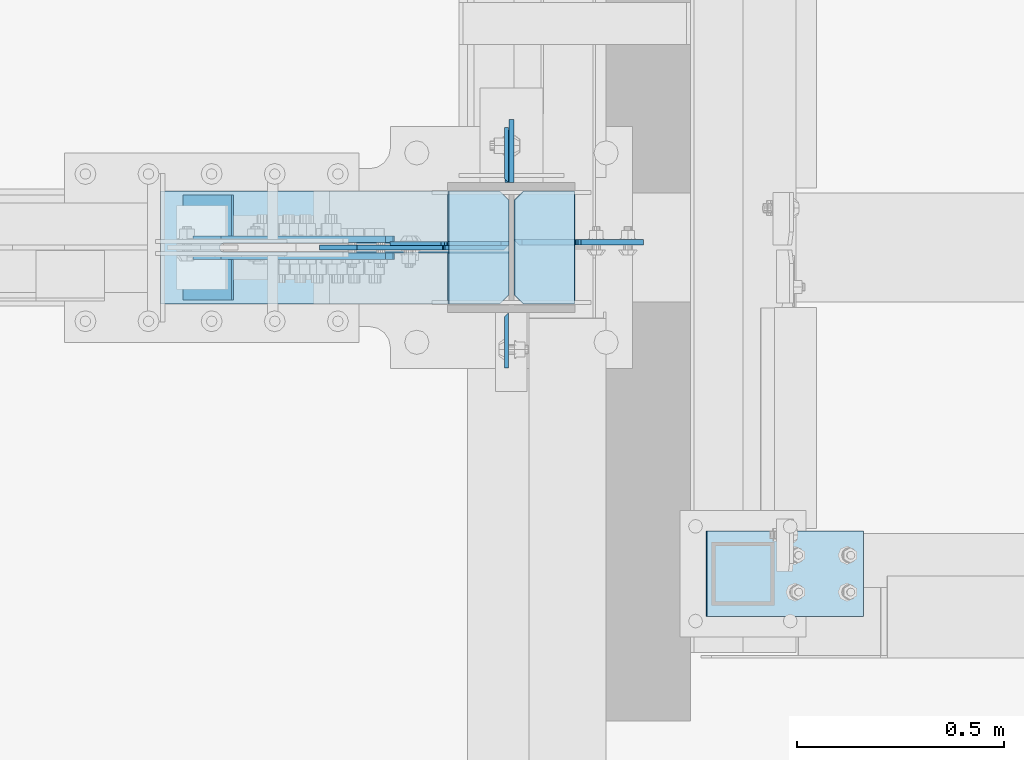
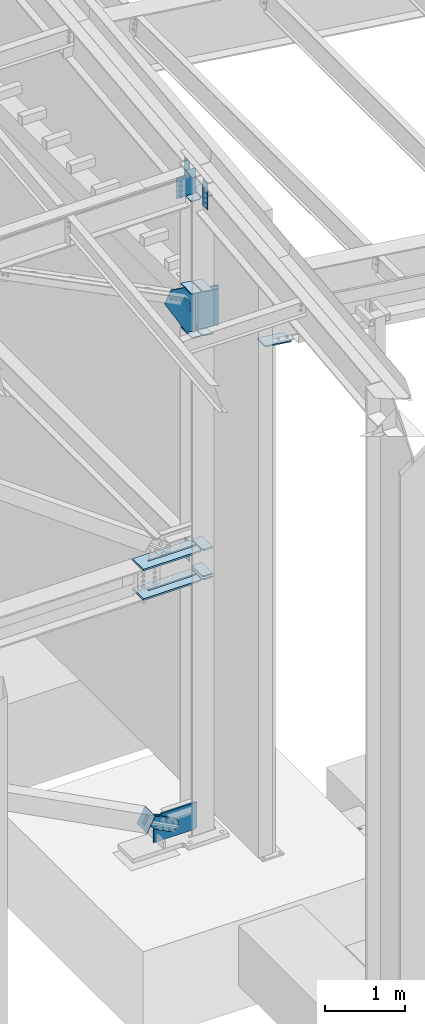
# One storey, part 1003 of 1179: 23 plates, 5 elements without a shape of their own.
"""IFC2X3 building model written with IfcOpenShell, lengths in millimetres."""

from ifc_helpers import new_model, si_unit, frame, origin_with_axes, place, context, subcontext, project, spatial, faceted_brep, material, type_object, element, aggregate, save


model = new_model("IFC2X3")

# Units and contexts
model_context = context("Model", 3, precision=1e-05, world=origin_with_axes())
body_context = subcontext(model_context, "Body", "Model", "MODEL_VIEW")
ifc_project = project(units=[si_unit("LENGTHUNIT", "METRE", prefix="MILLI"), si_unit("AREAUNIT", "SQUARE_METRE"), si_unit("VOLUMEUNIT", "CUBIC_METRE"), si_unit("MASSUNIT", "GRAM", prefix="KILO"), si_unit("TIMEUNIT", "SECOND"), si_unit("PLANEANGLEUNIT", "RADIAN"), si_unit("SOLIDANGLEUNIT", "STERADIAN"), si_unit("THERMODYNAMICTEMPERATUREUNIT", "DEGREE_CELSIUS"), si_unit("LUMINOUSINTENSITYUNIT", "LUMEN")], contexts=[model_context])

# Site, building, storey
site_placement = place(None, origin_with_axes())
site = spatial("IfcSite", under=ifc_project, at=site_placement, CompositionType="ELEMENT")
building_placement = place(site_placement, origin_with_axes())
building = spatial("IfcBuilding", under=site, at=building_placement, Name="Undefined", CompositionType="ELEMENT")
storey_placement = place(building_placement, origin_with_axes())
storey = spatial("IfcBuildingStorey", under=building, at=storey_placement, Name="Undefined", CompositionType="ELEMENT", Elevation=0.0)

# Assembly, plates
assembly_1_placement = place(storey_placement, origin_with_axes())
assembly_1 = element("IfcElementAssembly", 1, at=assembly_1_placement, inside=storey, Name="COLUMN", AssemblyPlace="NOTDEFINED", PredefinedType="RIGID_FRAME")
ifc_material_1 = material(Name="STEEL/A36")
plate_type_1 = type_object("IfcPlateType", PredefinedType="NOTDEFINED")
plate_1_placement = place(assembly_1_placement, frame((24297.48125, 5592.7625, 4051.29999886453), z_axis=(0.0, 1.0, 0.0), x_axis=(0.0, 0.0, -1.0)))
plate_1 = element("IfcPlate", 2, at=plate_1_placement, type_object=plate_type_1, material=ifc_material_1, Name="PLATE", context=body_context, shape_type="Brep", body=[
    faceted_brep([(0.0, -4.76249999999709, 0.0), (0.0, -4.76249999999709, 127.0), (0.0, 4.76249999999709, 127.0), (0.0, 4.76249999999709, 0.0), (304.799999999999, -4.76249999999982, 127.0), (304.799999999999, 4.76249999999982, 127.0), (304.799987792969, -4.76250000000073, 0.0), (304.799987792969, 4.76250000000073, 0.0)], [[[0, 1, 2, 3]], [[2, 1, 4, 5]], [[4, 6, 7, 5]], [[6, 0, 3, 7]], [[5, 7, 3, 2]], [[6, 4, 1, 0]]]),
])
ifc_material_2 = material(Name="STEEL/A572-GR.50")
plate_type_2 = type_object("IfcPlateType", PredefinedType="NOTDEFINED")
plate_2_placement = place(assembly_1_placement, frame((24314.15, 5299.075, 3641.725), z_axis=(0.0, 1.0, 0.0), x_axis=(1.0, 0.0, 0.0)))
plate_2 = element("IfcPlate", 3, at=plate_2_placement, type_object=plate_type_2, material=ifc_material_2, Name="PLATE", context=body_context, shape_type="Brep", body=[
    faceted_brep([(4.54747350886464e-12, -12.6999999999999, 22.2250003814697), (0.0, -12.6999999999998, 250.824987411499), (0.0, 12.6999999999998, 250.824987411499), (-4.54747350886464e-12, 12.6999999999999, 22.2250003814697), (22.2250003814697, -12.6999999999998, 273.049987792969), (22.2250003814697, 12.6999999999998, 273.049987792969), (146.050003051758, -12.6999999999998, 273.049987792969), (146.050003051758, 12.6999999999998, 273.049987792969), (146.050000000188, -12.7000000000003, 0.0), (146.050000000178, 12.6999999999995, 0.0), (22.2250003814834, -12.6999999999999, 0.0), (22.2250003814743, 12.6999999999998, 0.0)], [[[0, 1, 2, 3]], [[1, 4, 5, 2]], [[4, 6, 7, 5]], [[6, 8, 9, 7]], [[8, 10, 11, 9]], [[10, 0, 3, 11]], [[5, 7, 9, 11, 3, 2]], [[10, 8, 6, 4, 1, 0]]]),
])
plate_3_placement = place(assembly_1_placement, frame((24314.15, 5299.075, 4089.4), z_axis=(0.0, 1.0, 0.0), x_axis=(1.0, 0.0, 0.0)))
plate_3 = element("IfcPlate", 4, at=plate_3_placement, type_object=plate_type_2, material=ifc_material_2, Name="PLATE", context=body_context, shape_type="Brep", body=[
    faceted_brep([(4.54747350886464e-12, -12.6999999999999, 22.2250003814697), (0.0, -12.6999999999998, 250.824987411499), (0.0, 12.6999999999998, 250.824987411499), (-4.54747350886464e-12, 12.6999999999999, 22.2250003814697), (22.2250003814697, -12.6999999999998, 273.049987792969), (22.2250003814697, 12.6999999999998, 273.049987792969), (146.050003051758, -12.6999999999998, 273.049987792969), (146.050003051758, 12.6999999999998, 273.049987792969), (146.050000000188, -12.7000000000003, 0.0), (146.050000000178, 12.6999999999995, 0.0), (22.2250003814834, -12.6999999999999, 0.0), (22.2250003814743, 12.6999999999998, 0.0)], [[[0, 1, 2, 3]], [[1, 4, 5, 2]], [[4, 6, 7, 5]], [[6, 8, 9, 7]], [[8, 10, 11, 9]], [[10, 0, 3, 11]], [[5, 7, 9, 11, 3, 2]], [[10, 8, 6, 4, 1, 0]]]),
])
plate_type_3 = type_object("IfcPlateType", PredefinedType="NOTDEFINED")
plate_4_placement = place(assembly_1_placement, frame((24295.89375, 5592.76250000005, 9831.75045370011), z_axis=(0.0, 1.0, 0.0), x_axis=(0.0, 0.0, -1.0)))
plate_4 = element("IfcPlate", 5, at=plate_4_placement, type_object=plate_type_3, material=ifc_material_1, Name="PLATE", context=body_context, shape_type="Brep", body=[
    faceted_brep([(0.0, -4.76249999999709, 0.0), (0.0, 4.76250000000073, 9.52499999999964), (393.700000000001, 4.76250000000073, 9.52499999999964), (393.700000000001, -4.76250000000073, 0.0), (0.0, -4.76250000000073, 133.35), (0.0, 4.76250000000073, 133.35), (393.700000000001, -4.76250000000073, 133.35), (393.700000000001, 4.76250000000073, 133.35)], [[[0, 1, 2, 3]], [[4, 5, 1, 0]], [[4, 6, 7, 5]], [[7, 6, 3, 2]], [[5, 7, 2, 1]], [[3, 6, 4, 0]]]),
])
plate_5_placement = place(assembly_1_placement, frame((24295.89375, 5278.43749999996, 9776.14145226233), z_axis=(0.0, -1.0, 0.0), x_axis=(0.0, 0.0, -1.0)))
plate_5 = element("IfcPlate", 6, at=plate_5_placement, type_object=plate_type_3, material=ifc_material_1, Name="PLATE", context=body_context, shape_type="Brep", body=[
    faceted_brep([(-9.87109982941227e-13, -4.76250000012369, 9.52499961853027), (0.0, 4.76249999999709, 0.0), (393.700000000001, 4.76250000000073, 0.0), (393.700000000001, -4.76250000000073, 9.52499999999964), (0.0, -4.76250000000073, 133.35), (0.0, 4.76250000000073, 133.35), (393.700000000001, -4.76250000000073, 133.35), (393.700000000001, 4.76250000000073, 133.35)], [[[0, 1, 2, 3]], [[4, 5, 1, 0]], [[4, 6, 7, 5]], [[7, 6, 3, 2]], [[7, 2, 1, 5]], [[6, 4, 0, 3]]]),
])
plate_type_4 = type_object("IfcPlateType", PredefinedType="NOTDEFINED")
plate_6_placement = place(assembly_1_placement, frame((24301.4499999997, 5435.59999847412, 8300.5092897384), z_axis=(-1.0, 0.0, 0.0), x_axis=(0.0, 0.0, -1.0)))
plate_6 = element("IfcPlate", 7, at=plate_6_placement, type_object=plate_type_4, material=ifc_material_1, Name="PLATE", context=body_context, shape_type="Brep", body=[
    faceted_brep([(276.043491234429, -6.35000000000036, 0.0), (274.328637159171, 6.35000000000036, 12.700027727933), (921.15463263089, 6.35000000000036, 12.700027727933), (908.454604902959, -6.35000000000036, 0.0), (190.083008470575, -6.35000000000036, 366.146307044204), (190.083008470575, 6.35000000000036, 366.146307044204), (217.872874685361, 6.35000000000036, 160.337499999274), (217.872874685361, -6.35000000000036, 160.337499999274), (243.293103214405, 6.35000000000036, 160.337499999812), (243.293103214405, -6.35000000000036, 160.337499999812), (247.756823349011, 6.35000000000036, 159.527209931242), (247.756823349011, -6.35000000000036, 159.527209931242), (251.650951649207, 6.35000000000036, 157.19973657652), (251.650951649207, -6.35000000000036, 157.19973657652), (254.478578896849, 6.35000000000036, 153.652076561284), (254.478578896849, -6.35000000000036, 153.652076561284), (255.87888646027, 6.35000000000036, 149.336928109245), (255.87888646027, -6.35000000000036, 149.336928109245), (926.994320140947, 6.35000000000036, 18.5397152379883), (926.994320140947, -6.35000000000036, 18.5397152379883), (909.562557713552, -6.35000000000036, 147.637500196823), (371.832052203784, -6.35000000000036, 457.017235217187), (371.832052203784, 6.35000000000036, 457.017235217187), (909.562557713552, 6.35000000000036, 147.637500196823)], [[[0, 1, 2, 3]], [[4, 5, 6, 7]], [[7, 6, 8, 9]], [[9, 8, 10, 11]], [[11, 10, 12, 13]], [[13, 12, 14, 15]], [[15, 14, 16, 17]], [[17, 16, 1, 0]], [[18, 19, 3, 2]], [[4, 7, 9, 11, 13, 15, 17, 0, 3, 19, 20, 21]], [[5, 4, 21, 22]], [[16, 14, 12, 10, 8, 6, 5, 22, 23, 18, 2, 1]], [[19, 18, 23, 20]], [[22, 21, 20, 23]]]),
])
plate_type_5 = type_object("IfcPlateType", PredefinedType="NOTDEFINED")
plate_7_placement = place(assembly_1_placement, frame((24307.8, 5745.16249389649, 7696.20000000912), z_axis=(0.0, -1.0, 0.0), x_axis=(0.0, 0.0, -1.0)))
plate_7 = element("IfcPlate", 8, at=plate_7_placement, type_object=plate_type_5, material=ifc_material_1, Name="PLATE", context=body_context, shape_type="Brep", body=[
    faceted_brep([(0.0, -6.34999999999854, 0.0), (0.0, -6.34999999999854, 152.400000000001), (0.0, 6.34999999999854, 152.400000000001), (0.0, 6.34999999999854, 0.0), (152.399993896484, -6.34999999999854, 152.399993896484), (152.399993896484, 6.34999999999854, 152.399993896484), (152.399993896484, -6.34999999999854, 88.6901931762695), (152.399993896484, 6.34999999999854, 88.6901931762695), (63.5, -6.34999999999854, 0.0), (63.5, 6.34999999999854, 0.0)], [[[0, 1, 2, 3]], [[1, 4, 5, 2]], [[4, 6, 7, 5]], [[6, 8, 9, 7]], [[8, 0, 3, 9]], [[5, 7, 9, 3, 2]], [[8, 6, 4, 1, 0]]]),
])
plate_type_6 = type_object("IfcPlateType", PredefinedType="NOTDEFINED")
plate_8_placement = place(assembly_1_placement, frame((23460.5754788212, 5572.12499999999, 3641.725), z_axis=(0.0, -1.0, 0.0), x_axis=(1.0, 0.0, 0.0)))
plate_8 = element("IfcPlate", 9, at=plate_8_placement, type_object=plate_type_6, material=ifc_material_2, Name="PLATE", context=body_context, shape_type="Brep", body=[
    faceted_brep([(0.0, -12.7, 0.0), (0.0, -12.6999999999998, 273.050006103513), (0.0, 12.6999999999998, 273.050006103513), (0.0, 12.7, 0.0), (818.629588224077, -12.6999999999998, 273.050006103513), (818.629588224077, 12.6999999999998, 273.050006103513), (840.854588605547, -12.6999999999998, 250.825005722043), (840.854588605547, 12.6999999999998, 250.825005722043), (840.854588605547, -12.6999999999998, 147.637499999997), (840.854588605547, 12.6999999999998, 147.637499999997), (153.987500190735, -12.6999999999998, 147.637499999997), (153.987500190735, 12.6999999999998, 147.637499999997), (149.734930475588, -12.6999999999998, 146.79161129051), (149.734930475588, 12.6999999999998, 146.79161129051), (146.129775949928, -12.6999999999998, 144.382724050068), (146.129775949928, 12.6999999999998, 144.382724050068), (143.720888709486, -12.6999999999998, 140.77756952441), (143.720888709486, 12.6999999999998, 140.77756952441), (142.875, -12.6999999999998, 136.525000190733), (142.875, 12.6999999999998, 136.525000190733), (143.720888709486, -12.6999999999998, 132.272430475586), (143.720888709486, 12.6999999999998, 132.272430475586), (146.129775949928, -12.6999999999998, 128.667275949928), (146.129775949928, 12.6999999999998, 128.667275949928), (149.734930475588, -12.6999999999998, 126.258388709486), (149.734930475588, 12.6999999999998, 126.258388709486), (153.987500190735, -12.6999999999998, 125.412499999999), (153.987500190735, 12.6999999999998, 125.412499999999), (840.854588605547, -12.6999999999998, 125.412499999999), (840.854588605547, 12.6999999999998, 125.412499999999), (840.854588605547, -12.6999999999998, 22.2250003814697), (840.854588605547, 12.6999999999998, 22.2250003814697), (818.629588224077, -12.6999999999998, 0.0), (818.629588224077, 12.6999999999998, 0.0)], [[[0, 1, 2, 3]], [[1, 4, 5, 2]], [[4, 6, 7, 5]], [[6, 8, 9, 7]], [[8, 10, 11, 9]], [[10, 12, 13, 11]], [[12, 14, 15, 13]], [[14, 16, 17, 15]], [[16, 18, 19, 17]], [[18, 20, 21, 19]], [[20, 22, 23, 21]], [[22, 24, 25, 23]], [[24, 26, 27, 25]], [[26, 28, 29, 27]], [[28, 30, 31, 29]], [[30, 32, 33, 31]], [[32, 0, 3, 33]], [[5, 7, 9, 11, 13, 15, 17, 19, 21, 23, 25, 27, 29, 31, 33, 3, 2]], [[32, 30, 28, 26, 24, 22, 20, 18, 16, 14, 12, 10, 8, 6, 4, 1, 0]]]),
])
plate_9_placement = place(assembly_1_placement, frame((23460.5754788212, 5572.12499999999, 4089.4), z_axis=(0.0, -1.0, 0.0), x_axis=(1.0, 0.0, 0.0)))
plate_9 = element("IfcPlate", 10, at=plate_9_placement, type_object=plate_type_6, material=ifc_material_2, Name="PLATE", context=body_context, shape_type="Brep", body=[
    faceted_brep([(0.0, -12.7, 0.0), (0.0, -12.6999999999998, 273.050006103513), (0.0, 12.6999999999998, 273.050006103513), (0.0, 12.7, 0.0), (818.629588224077, -12.6999999999998, 273.050006103513), (818.629588224077, 12.6999999999998, 273.050006103513), (840.854588605547, -12.6999999999998, 250.825005722043), (840.854588605547, 12.6999999999998, 250.825005722043), (840.854588605547, -12.6999999999998, 147.637499999997), (840.854588605547, 12.6999999999998, 147.637499999997), (153.987500190735, -12.6999999999998, 147.637499999997), (153.987500190735, 12.6999999999998, 147.637499999997), (149.734930475588, -12.6999999999998, 146.79161129051), (149.734930475588, 12.6999999999998, 146.79161129051), (146.129775949928, -12.6999999999998, 144.382724050068), (146.129775949928, 12.6999999999998, 144.382724050068), (143.720888709486, -12.6999999999998, 140.77756952441), (143.720888709486, 12.6999999999998, 140.77756952441), (142.875, -12.6999999999998, 136.525000190733), (142.875, 12.6999999999998, 136.525000190733), (143.720888709486, -12.6999999999998, 132.272430475586), (143.720888709486, 12.6999999999998, 132.272430475586), (146.129775949928, -12.6999999999998, 128.667275949928), (146.129775949928, 12.6999999999998, 128.667275949928), (149.734930475588, -12.6999999999998, 126.258388709486), (149.734930475588, 12.6999999999998, 126.258388709486), (153.987500190735, -12.6999999999998, 125.412499999999), (153.987500190735, 12.6999999999998, 125.412499999999), (840.854588605547, -12.6999999999998, 125.412499999999), (840.854588605547, 12.6999999999998, 125.412499999999), (840.854588605547, -12.6999999999998, 22.2250003814697), (840.854588605547, 12.6999999999998, 22.2250003814697), (818.629588224077, -12.6999999999998, 0.0), (818.629588224077, 12.6999999999998, 0.0)], [[[0, 1, 2, 3]], [[1, 4, 5, 2]], [[4, 6, 7, 5]], [[6, 8, 9, 7]], [[8, 10, 11, 9]], [[10, 12, 13, 11]], [[12, 14, 15, 13]], [[14, 16, 17, 15]], [[16, 18, 19, 17]], [[18, 20, 21, 19]], [[20, 22, 23, 21]], [[22, 24, 25, 23]], [[24, 26, 27, 25]], [[26, 28, 29, 27]], [[28, 30, 31, 29]], [[30, 32, 33, 31]], [[32, 0, 3, 33]], [[5, 7, 9, 11, 13, 15, 17, 19, 21, 23, 25, 27, 29, 31, 33, 3, 2]], [[32, 30, 28, 26, 24, 22, 20, 18, 16, 14, 12, 10, 8, 6, 4, 1, 0]]]),
])
plate_type_7 = type_object("IfcPlateType", PredefinedType="NOTDEFINED")
plate_10_placement = place(assembly_1_placement, frame((24300.6002860282, 5299.075, 7364.7187048942), z_axis=(0.0, 1.0, 0.0), x_axis=(-0.99100656978554, 0.0, 0.133813222971043)))
plate_10 = element("IfcPlate", 11, at=plate_10_placement, type_object=plate_type_7, material=ifc_material_1, Name="PLATE", context=body_context, shape_type="Brep", body=[
    faceted_brep([(0.0, -6.34999999999854, 22.2250003814697), (0.0, -6.35000000000036, 250.82499961853), (0.0, 6.35000000000036, 250.82499961853), (0.0, 6.34999999999854, 22.2250003814697), (22.2250003814697, -6.35000000000036, 273.05), (22.2250003814697, 6.35000000000036, 273.05), (146.050003051758, -6.35000000000036, 273.049987792969), (146.050003051758, 6.35000000000036, 273.049987792969), (146.050003051758, -6.35000000000036, 0.0), (146.050003051758, 6.35000000000036, 0.0), (22.2250003814697, -6.34999999999854, 0.0), (22.2250003814697, 6.34999999999854, 0.0)], [[[0, 1, 2, 3]], [[1, 4, 5, 2]], [[4, 6, 7, 5]], [[6, 8, 9, 7]], [[8, 10, 11, 9]], [[10, 0, 3, 11]], [[5, 7, 9, 11, 3, 2]], [[10, 8, 6, 4, 1, 0]]]),
])
plate_11_placement = place(assembly_1_placement, frame((24300.6002860276, 5299.075, 8032.57565987269), z_axis=(0.0, 1.0, 0.0), x_axis=(-0.99100656978554, 0.0, 0.133813222971043)))
plate_11 = element("IfcPlate", 12, at=plate_11_placement, type_object=plate_type_7, material=ifc_material_1, Name="PLATE", context=body_context, shape_type="Brep", body=[
    faceted_brep([(0.0, -6.34999999999854, 22.2250003814697), (0.0, -6.35000000000036, 250.82499961853), (0.0, 6.35000000000036, 250.82499961853), (0.0, 6.34999999999854, 22.2250003814697), (22.2250003814697, -6.35000000000036, 273.05), (22.2250003814697, 6.35000000000036, 273.05), (146.050003051758, -6.35000000000036, 273.049987792969), (146.050003051758, 6.35000000000036, 273.049987792969), (146.050003051758, -6.35000000000036, 0.0), (146.050003051758, 6.35000000000036, 0.0), (22.2250003814697, -6.34999999999854, 0.0), (22.2250003814697, 6.34999999999854, 0.0)], [[[0, 1, 2, 3]], [[1, 4, 5, 2]], [[4, 6, 7, 5]], [[6, 8, 9, 7]], [[8, 10, 11, 9]], [[10, 0, 3, 11]], [[5, 7, 9, 11, 3, 2]], [[10, 8, 6, 4, 1, 0]]]),
])
plate_12_placement = place(assembly_1_placement, frame((24459.73622347, 5299.075, 8011.0879185318), z_axis=(0.0, 1.0, 0.0), x_axis=(-0.99100656978554, 0.0, 0.133813222971043)))
plate_12 = element("IfcPlate", 13, at=plate_12_placement, type_object=plate_type_7, material=ifc_material_1, Name="PLATE", context=body_context, shape_type="Brep", body=[
    faceted_brep([(0.0, -6.34999999999854, 0.0), (0.0, -6.34999999999991, 273.05), (0.0, 6.34999999999991, 273.05), (0.0, 6.34999999999854, 0.0), (123.824999618599, -6.34999999999991, 273.05), (123.824999618599, 6.34999999999991, 273.05), (146.050000000068, -6.34999999999991, 250.82499961853), (146.050000000068, 6.34999999999991, 250.82499961853), (146.050000000068, -6.34999999999991, 22.2250003814697), (146.050000000068, 6.34999999999991, 22.2250003814697), (123.824999618599, -6.34999999999991, 0.0), (123.824999618599, 6.34999999999991, 0.0)], [[[0, 1, 2, 3]], [[1, 4, 5, 2]], [[4, 6, 7, 5]], [[6, 8, 9, 7]], [[8, 10, 11, 9]], [[10, 0, 3, 11]], [[5, 7, 9, 11, 3, 2]], [[10, 8, 6, 4, 1, 0]]]),
])
plate_13_placement = place(assembly_1_placement, frame((24459.7362234703, 5299.075, 7343.23096355331), z_axis=(0.0, 1.0, 0.0), x_axis=(-0.99100656978554, 0.0, 0.133813222971043)))
plate_13 = element("IfcPlate", 14, at=plate_13_placement, type_object=plate_type_7, material=ifc_material_1, Name="PLATE", context=body_context, shape_type="Brep", body=[
    faceted_brep([(0.0, -6.34999999999854, 0.0), (0.0, -6.34999999999991, 273.05), (0.0, 6.34999999999991, 273.05), (0.0, 6.34999999999854, 0.0), (123.824999618599, -6.34999999999991, 273.05), (123.824999618599, 6.34999999999991, 273.05), (146.050000000068, -6.34999999999991, 250.82499961853), (146.050000000068, 6.34999999999991, 250.82499961853), (146.050000000068, -6.34999999999991, 22.2250003814697), (146.050000000068, 6.34999999999991, 22.2250003814697), (123.824999618599, -6.34999999999991, 0.0), (123.824999618599, 6.34999999999991, 0.0)], [[[0, 1, 2, 3]], [[1, 4, 5, 2]], [[4, 6, 7, 5]], [[6, 8, 9, 7]], [[8, 10, 11, 9]], [[10, 0, 3, 11]], [[5, 7, 9, 11, 3, 2]], [[10, 8, 6, 4, 1, 0]]]),
])
plate_14_placement = place(assembly_1_placement, frame((24460.2, 5299.075, 3692.525), z_axis=(0.0, 1.0, 0.0), x_axis=(-1.0, 0.0, 0.0)))
plate_14 = element("IfcPlate", 15, at=plate_14_placement, type_object=plate_type_7, material=ifc_material_1, Name="PLATE", context=body_context, shape_type="Brep", body=[
    faceted_brep([(0.0, -6.34999999999854, 0.0), (0.0, -6.34999999999991, 273.05), (0.0, 6.34999999999991, 273.05), (0.0, 6.34999999999854, 0.0), (123.824999618599, -6.34999999999991, 273.05), (123.824999618599, 6.34999999999991, 273.05), (146.050000000068, -6.34999999999991, 250.82499961853), (146.050000000068, 6.34999999999991, 250.82499961853), (146.050000000068, -6.34999999999991, 22.2250003814697), (146.050000000068, 6.34999999999991, 22.2250003814697), (123.824999618599, -6.34999999999991, 0.0), (123.824999618599, 6.34999999999991, 0.0)], [[[0, 1, 2, 3]], [[1, 4, 5, 2]], [[4, 6, 7, 5]], [[6, 8, 9, 7]], [[8, 10, 11, 9]], [[10, 0, 3, 11]], [[5, 7, 9, 11, 3, 2]], [[10, 8, 6, 4, 1, 0]]]),
])

# Assembly, plate
assembly_2_placement = place(storey_placement, origin_with_axes())
assembly_2 = element("IfcElementAssembly", 16, at=assembly_2_placement, inside=storey, Name="COLUMN", AssemblyPlace="NOTDEFINED", PredefinedType="RIGID_FRAME")
plate_type_8 = type_object("IfcPlateType", PredefinedType="NOTDEFINED")
plate_15_placement = place(assembly_2_placement, frame((25156.3716709665, 4751.3875, 7441.48354890872), z_axis=(-0.99100656978554, 0.0, 0.133813222971043), x_axis=(0.0, -1.0, 0.0)))
plate_15 = element("IfcPlate", 17, at=plate_15_placement, type_object=plate_type_8, material=ifc_material_1, Name="PLATE", context=body_context, shape_type="Brep", body=[
    faceted_brep([(0.0, -9.52499999999964, 0.0), (0.0, -9.52499999989595, 381.000000000437), (0.0, 9.52500000011059, 381.000000000415), (0.0, 9.52499999999964, 0.0), (206.375, -9.52499999989595, 381.000000000437), (206.375, 9.52500000011059, 381.000000000415), (206.374999618529, -9.52499999999964, 0.0), (206.374999618529, 9.52499999999964, 0.0)], [[[0, 1, 2, 3]], [[1, 4, 5, 2]], [[4, 6, 7, 5]], [[6, 0, 3, 7]], [[5, 7, 3, 2]], [[6, 4, 1, 0]]]),
])
aggregate(assembly_2, [plate_15])

assembly_3_placement = place(storey_placement, origin_with_axes())
assembly_3 = element("IfcElementAssembly", 18, at=assembly_3_placement, inside=storey, Name="Plate", AssemblyPlace="NOTDEFINED", PredefinedType="RIGID_FRAME")
plate_type_9 = type_object("IfcPlateType", PredefinedType="NOTDEFINED")
plate_16_placement = place(assembly_3_placement, frame((23517.0183300644, 5562.6, 52.179971113252), z_axis=(0.461369686935621, 0.0, 0.887207986876204), x_axis=(0.0, -1.0, 0.0)))
plate_16 = element("IfcPlate", 19, at=plate_16_placement, type_object=plate_type_9, material=ifc_material_1, Name="Plate", context=body_context, shape_type="Brep", body=[
    faceted_brep([(0.0, -3.17500000000109, 0.0), (0.0, -3.17499999986103, 253.99999999967), (0.0, 3.17500000013752, 253.999999999668), (0.0, 3.17500000000109, 7.27595761418343e-12), (254.0, -3.17499999986103, 253.99999999967), (254.0, 3.17500000013752, 253.999999999668), (254.0, -3.17500000000109, 9.09494701772928e-13), (254.0, 3.17499999999745, -1.36424205265939e-12)], [[[0, 1, 2, 3]], [[1, 4, 5, 2]], [[4, 6, 7, 5]], [[6, 0, 3, 7]], [[5, 7, 3, 2]], [[6, 4, 1, 0]]]),
])
aggregate(assembly_3, [plate_16])

assembly_4_placement = place(storey_placement, origin_with_axes())
assembly_4 = element("IfcElementAssembly", 20, at=assembly_4_placement, inside=storey, AssemblyPlace="NOTDEFINED", PredefinedType="RIGID_FRAME")
plate_type_10 = type_object("IfcPlateType", PredefinedType="NOTDEFINED")
plate_17_placement = place(assembly_4_placement, frame((23606.6841150405, 5456.2375, 231.487808018184), z_axis=(-0.461369686935624, 0.0, -0.887207986876203), x_axis=(0.887207986876203, 0.0, -0.461369686935623)))
plate_17 = element("IfcPlate", 21, at=plate_17_placement, type_object=plate_type_10, material=ifc_material_1, context=body_context, shape_type="Brep", body=[
    faceted_brep([(0.0, -7.9375, 0.0), (-8.00355337560177e-11, -7.9375, 146.904840309817), (-8.00355337560177e-11, 7.9375, 146.904840309817), (0.0, 7.9375, 0.0), (82.5499999998137, -7.9375, 146.90484031055), (82.5499999998137, 7.9375, 146.90484031055), (184.150000000214, -7.9375, 168.702420155054), (184.150000000214, 7.9375, 168.702420155054), (403.471138850085, -7.9375, 168.70242015493), (403.471138850085, 7.9375, 168.70242015493), (439.921735782846, -7.9375, 161.451945626626), (439.921735782846, 7.9375, 161.451945626626), (470.823059758064, -7.9375, 140.804341062974), (470.823059758064, 7.9375, 140.804341062974), (491.470664321725, -7.9375, 109.903017087783), (491.470664321725, 7.9375, 109.903017087783), (498.721138850011, -7.9375, 73.4524201549993), (498.721138850011, 7.9375, 73.4524201549993), (491.470664321694, -7.9375, 37.001823222241), (491.470664321694, 7.9375, 37.001823222241), (470.82305975797, -7.9375, 6.10049924700979), (470.82305975797, 7.9375, 6.10049924700979), (439.921735782676, -7.9375, -14.5471053166548), (439.921735782676, 7.9375, -14.5471053166548), (403.471138849898, -7.9375, -21.7975798449352), (403.471138849898, 7.9375, -21.7975798449352), (184.150000000169, -7.9375, -21.7975798448115), (184.150000000169, 7.9375, -21.7975798448115), (82.5500000000975, -7.9375, -6.91215973347425e-11), (82.5500000000975, 7.9375, -6.91215973347425e-11)], [[[0, 1, 2, 3]], [[1, 4, 5, 2]], [[4, 6, 7, 5]], [[6, 8, 9, 7]], [[8, 10, 11, 9]], [[10, 12, 13, 11]], [[12, 14, 15, 13]], [[14, 16, 17, 15]], [[16, 18, 19, 17]], [[18, 20, 21, 19]], [[20, 22, 23, 21]], [[22, 24, 25, 23]], [[24, 26, 27, 25]], [[26, 28, 29, 27]], [[28, 0, 3, 29]], [[5, 7, 9, 11, 13, 15, 17, 19, 21, 23, 25, 27, 29, 3, 2]], [[28, 26, 24, 22, 20, 18, 16, 14, 12, 10, 8, 6, 4, 1, 0]]]),
])
aggregate(assembly_4, [plate_17])

assembly_5_placement = place(storey_placement, origin_with_axes())
assembly_5 = element("IfcElementAssembly", 22, at=assembly_5_placement, inside=storey, AssemblyPlace="NOTDEFINED", PredefinedType="RIGID_FRAME")
plate_18_placement = place(assembly_5_placement, frame((23606.6841150405, 5414.9625, 231.487808018184), z_axis=(-0.461369686935624, 0.0, -0.887207986876203), x_axis=(0.887207986876203, 0.0, -0.461369686935623)))
plate_18 = element("IfcPlate", 23, at=plate_18_placement, type_object=plate_type_10, material=ifc_material_1, context=body_context, shape_type="Brep", body=[
    faceted_brep([(0.0, -7.9375, 0.0), (-8.00355337560177e-11, -7.9375, 146.904840309817), (-8.00355337560177e-11, 7.9375, 146.904840309817), (0.0, 7.9375, 0.0), (82.5499999998137, -7.9375, 146.90484031055), (82.5499999998137, 7.9375, 146.90484031055), (184.150000000214, -7.9375, 168.702420155054), (184.150000000214, 7.9375, 168.702420155054), (403.471138850085, -7.9375, 168.70242015493), (403.471138850085, 7.9375, 168.70242015493), (439.921735782846, -7.9375, 161.451945626626), (439.921735782846, 7.9375, 161.451945626626), (470.823059758064, -7.9375, 140.804341062974), (470.823059758064, 7.9375, 140.804341062974), (491.470664321725, -7.9375, 109.903017087783), (491.470664321725, 7.9375, 109.903017087783), (498.721138850011, -7.9375, 73.4524201549993), (498.721138850011, 7.9375, 73.4524201549993), (491.470664321694, -7.9375, 37.001823222241), (491.470664321694, 7.9375, 37.001823222241), (470.82305975797, -7.9375, 6.10049924700979), (470.82305975797, 7.9375, 6.10049924700979), (439.921735782676, -7.9375, -14.5471053166548), (439.921735782676, 7.9375, -14.5471053166548), (403.471138849898, -7.9375, -21.7975798449352), (403.471138849898, 7.9375, -21.7975798449352), (184.150000000169, -7.9375, -21.7975798448115), (184.150000000169, 7.9375, -21.7975798448115), (82.5500000000975, -7.9375, -6.91215973347425e-11), (82.5500000000975, 7.9375, -6.91215973347425e-11)], [[[0, 1, 2, 3]], [[1, 4, 5, 2]], [[4, 6, 7, 5]], [[6, 8, 9, 7]], [[8, 10, 11, 9]], [[10, 12, 13, 11]], [[12, 14, 15, 13]], [[14, 16, 17, 15]], [[16, 18, 19, 17]], [[18, 20, 21, 19]], [[20, 22, 23, 21]], [[22, 24, 25, 23]], [[24, 26, 27, 25]], [[26, 28, 29, 27]], [[28, 0, 3, 29]], [[5, 7, 9, 11, 13, 15, 17, 19, 21, 23, 25, 27, 29, 3, 2]], [[28, 26, 24, 22, 20, 18, 16, 14, 12, 10, 8, 6, 4, 1, 0]]]),
])
aggregate(assembly_5, [plate_18])

# Plate
plate_type_11 = type_object("IfcPlateType", PredefinedType="NOTDEFINED")
plate_19_placement = place(assembly_1_placement, frame((24301.4500268074, 5435.6, -215.900033118258), z_axis=(0.0, 0.0, 1.0), x_axis=(-1.0, 0.0, 0.0)))
plate_19 = element("IfcPlate", 24, at=plate_19_placement, type_object=plate_type_11, material=ifc_material_2, Name="PLATE", context=body_context, shape_type="Brep", body=[
    faceted_brep([(0.0, -12.7000000000007, 19.0500000000029), (2.68073781626299e-05, -12.6999999999998, 404.300683084855), (2.68073781626299e-05, 12.6999999999998, 404.300683084855), (0.0, 12.7000000000007, 19.0500000000029), (509.611028343264, -12.6999999999998, 404.300683084855), (509.611028343264, 12.6999999999998, 404.300683084855), (620.939533800829, -12.6999999999998, 190.217395851627), (620.939533800829, 12.6999999999998, 190.217395851627), (620.939506993451, -12.6999999999998, 0.0), (620.939506993451, 12.6999999999998, 0.0), (19.0499992370605, -12.6999999999971, 0.0), (19.0499992370605, 12.6999999999971, 0.0)], [[[0, 1, 2, 3]], [[1, 4, 5, 2]], [[4, 6, 7, 5]], [[6, 8, 9, 7]], [[8, 10, 11, 9]], [[10, 0, 3, 11]], [[5, 7, 9, 11, 3, 2]], [[10, 8, 6, 4, 1, 0]]]),
])

plate_type_12 = type_object("IfcPlateType", PredefinedType="NOTDEFINED")
plate_20_placement = place(assembly_1_placement, frame((24314.15, 5572.125, 9458.6162842795), z_axis=(0.0, -1.0, 0.0), x_axis=(1.0, 0.0, 0.0)))
plate_20 = element("IfcPlate", 25, at=plate_20_placement, type_object=plate_type_12, material=ifc_material_1, Name="PLATE", context=body_context, shape_type="Brep", body=[
    faceted_brep([(0.0, -6.34999999999854, 22.2250003814697), (0.0, -6.35000000000036, 250.82499961853), (0.0, 6.35000000000036, 250.82499961853), (0.0, 6.34999999999854, 22.2250003814697), (22.2250003814697, -6.35000000000036, 273.05), (22.2250003814697, 6.35000000000036, 273.05), (147.637500000001, -6.35000000000036, 273.05), (147.637500000001, 6.35000000000036, 273.05), (147.637500000001, -6.35000000000036, 0.0), (147.637500000001, 6.35000000000036, 0.0), (22.2250003814697, -6.34999999999854, 0.0), (22.2250003814697, 6.34999999999854, 0.0)], [[[0, 1, 2, 3]], [[1, 4, 5, 2]], [[4, 6, 7, 5]], [[6, 8, 9, 7]], [[8, 10, 11, 9]], [[10, 0, 3, 11]], [[5, 7, 9, 11, 3, 2]], [[10, 8, 6, 4, 1, 0]]]),
])

plate_21_placement = place(assembly_1_placement, frame((24153.8125, 5572.125, 9458.6162842795), z_axis=(0.0, -1.0, 0.0), x_axis=(1.0, 0.0, 0.0)))
plate_21 = element("IfcPlate", 26, at=plate_21_placement, type_object=plate_type_12, material=ifc_material_1, Name="PLATE", context=body_context, shape_type="Brep", body=[
    faceted_brep([(0.0, -6.34999999999854, 0.0), (0.0, -6.34999999999991, 273.05), (0.0, 6.34999999999991, 273.05), (0.0, 6.34999999999854, 0.0), (125.412499618531, -6.35000000000036, 273.05), (125.412499618531, 6.35000000000036, 273.05), (147.637500000001, -6.35000000000036, 250.82499961853), (147.637500000001, 6.35000000000036, 250.82499961853), (147.637500000001, -6.35000000000036, 22.2250003814697), (147.637500000001, 6.35000000000036, 22.2250003814697), (125.412499618531, -6.35000000000036, 0.0), (125.412499618531, 6.35000000000036, 0.0)], [[[0, 1, 2, 3]], [[1, 4, 5, 2]], [[4, 6, 7, 5]], [[6, 8, 9, 7]], [[8, 10, 11, 9]], [[10, 0, 3, 11]], [[5, 7, 9, 11, 3, 2]], [[10, 8, 6, 4, 1, 0]]]),
])

plate_type_13 = type_object("IfcPlateType", PredefinedType="NOTDEFINED")
plate_22_placement = place(assembly_1_placement, frame((24301.45, 5445.92858457244, 9484.0162842795), z_axis=(-0.707106781186532, 0.0, 0.707106781186563), x_axis=(-0.707106781186564, 0.0, -0.707106781186531)))
plate_22 = element("IfcPlate", 27, at=plate_22_placement, type_object=plate_type_13, material=ifc_material_1, Name="PLATE", context=body_context, shape_type="Brep", body=[
    faceted_brep([(0.0, -4.76249999999709, 0.0), (-244.571689313841, -4.76249999999982, 244.571689313816), (-244.571689313841, 4.76249999999982, 244.571689313816), (0.0, 4.76249999999709, 0.0), (-244.571689313907, -4.76249999999982, 271.512457676967), (-244.571689313907, 4.76249999999982, 271.512457676967), (-153.646596088525, -4.76249999999982, 362.437550902356), (-153.646596088525, 4.76249999999982, 362.437550902356), (-124.601053410686, -4.76249999999982, 333.392008224517), (-124.601053410686, 4.76249999999982, 333.392008224517), (-116.360700474379, -4.76249999999982, 327.885980423558), (-116.360700474379, 4.76249999999982, 327.885980423558), (-106.640541438297, -4.76249999999982, 325.952520578376), (-106.640541438297, 4.76249999999982, 325.952520578376), (-96.9203824022152, -4.76249999999982, 327.885980423536), (-96.9203824022152, 4.76249999999982, 327.885980423536), (-88.6800294659261, -4.76249999999982, 333.392008224477), (-88.6800294659261, 4.76249999999982, 333.392008224477), (-7.85772410699792, -4.76249999999982, 414.214313583412), (-7.85772410699792, 4.76249999999982, 414.214313583412), (216.648678919817, -4.76249999999982, 189.707910556617), (216.648678919817, 4.76249999999982, 189.707910556617), (26.9407683631525, -4.76249999999709, -6.18456397205591e-11), (26.9407683631525, 4.76249999999709, -6.18456397205591e-11)], [[[0, 1, 2, 3]], [[1, 4, 5, 2]], [[4, 6, 7, 5]], [[6, 8, 9, 7]], [[8, 10, 11, 9]], [[10, 12, 13, 11]], [[12, 14, 15, 13]], [[14, 16, 17, 15]], [[16, 18, 19, 17]], [[18, 20, 21, 19]], [[20, 22, 23, 21]], [[22, 0, 3, 23]], [[5, 7, 9, 11, 13, 15, 17, 19, 21, 23, 3, 2]], [[22, 20, 18, 16, 14, 12, 10, 8, 6, 4, 1, 0]]]),
])

plate_type_14 = type_object("IfcPlateType", PredefinedType="NOTDEFINED")
plate_23_placement = place(assembly_1_placement, frame((24314.15, 5448.29999990464, 8023.77021653002), z_axis=(1.0, 0.0, 0.0), x_axis=(0.0, 0.0, -1.0)))
plate_23 = element("IfcPlate", 28, at=plate_23_placement, type_object=plate_type_14, material=ifc_material_1, Name="PLATE", context=body_context, shape_type="Brep", body=[
    faceted_brep([(634.527908149404, 6.35000000000036, 0.0), (649.058011348407, -6.35000000000036, 12.6999998092651), (7.94959664897669, -6.35000000000036, 12.6999998092651), (19.0500000000002, 6.35000000000036, 0.0), (36.1800891822249, -6.35000000000036, 147.63749999999), (36.1800891822249, 6.35000000000036, 147.63749999999), (19.9351351003643, 6.35000000000036, 147.63749999999), (19.9351351003643, -6.35000000000036, 147.63749999999), (45.1075294512666, -6.35000000000036, 149.258080137297), (45.1075294512666, 6.35000000000036, 149.258080137297), (52.8957860514674, -6.35000000000036, 153.913026846782), (52.8957860514674, 6.35000000000036, 153.913026846782), (58.5510405466011, -6.35000000000036, 161.008346877199), (58.5510405466011, 6.35000000000036, 161.008346877199), (61.3516556733703, -6.35000000000036, 169.638643781156), (61.3516556733703, 6.35000000000036, 169.638643781156), (80.6739486641782, -6.35000000000036, 312.737500000003), (80.6739486641782, 6.35000000000036, 312.737500000003), (2.54914181421555, -6.35000000000036, 18.8786743958117), (2.54914181421555, 6.35000000000036, 18.8786743958117), (656.12704920068, 6.35000000000036, 18.8786743958117), (656.12704920068, -6.35000000000036, 18.8786743958117), (695.806096792616, -6.35000000000036, 312.737500000003), (695.806096792616, 6.35000000000036, 312.737500000003)], [[[0, 1, 2, 3]], [[4, 5, 6, 7]], [[8, 9, 5, 4]], [[10, 11, 9, 8]], [[12, 13, 11, 10]], [[14, 15, 13, 12]], [[16, 17, 15, 14]], [[18, 19, 3, 2]], [[20, 21, 1, 0]], [[22, 21, 20, 23]], [[21, 22, 16, 14, 12, 10, 8, 4, 7, 18, 2, 1]], [[19, 18, 7, 6]], [[23, 20, 0, 3, 19, 6, 5, 9, 11, 13, 15, 17]], [[22, 23, 17, 16]]]),
])

aggregate(assembly_1, [plate_4, plate_5, plate_6, plate_2, plate_3, plate_8, plate_9, plate_19, plate_20, plate_21, plate_22, plate_10, plate_11, plate_12, plate_13, plate_23, plate_14, plate_1, plate_7])

save(model, "model.ifc")
